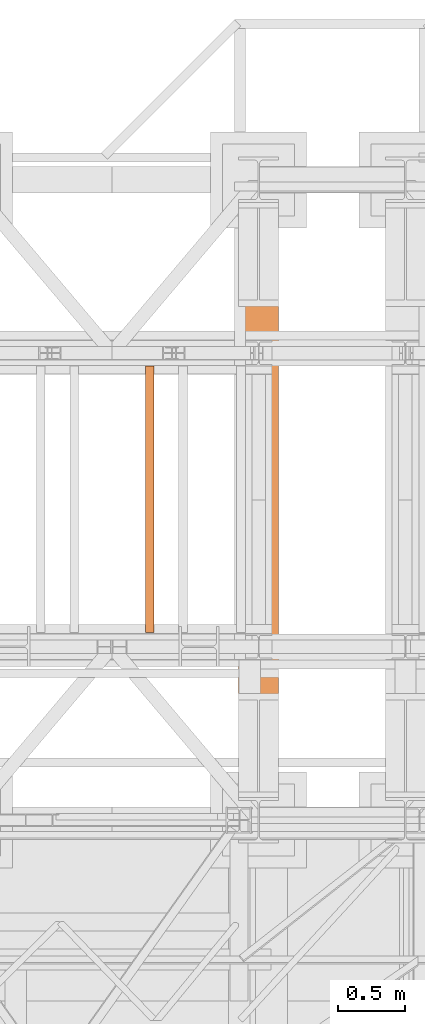
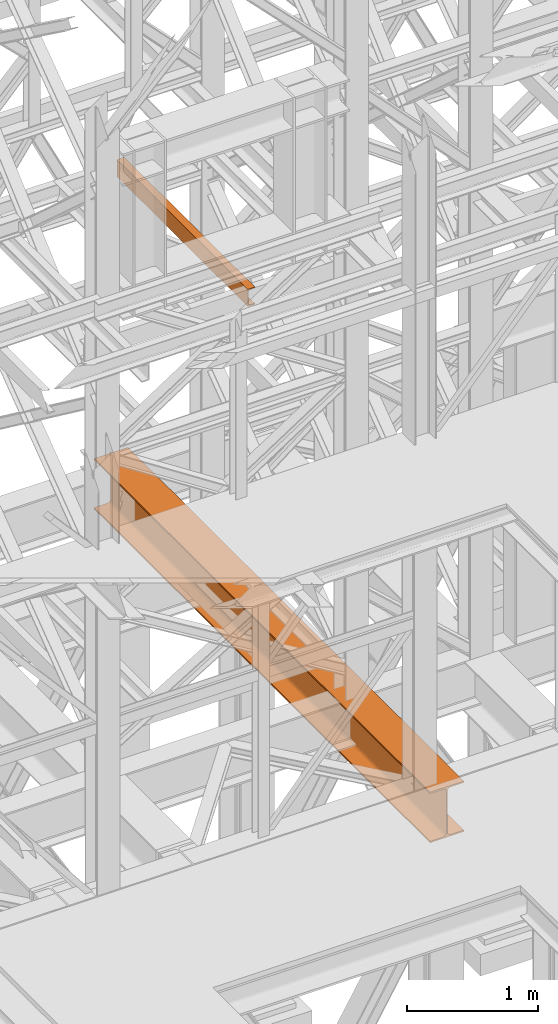
# One storey, part 159 of 208: 2 proxies.
"""IFC2X3 building model written with IfcOpenShell, lengths in millimetres."""

from ifc_helpers import new_model, entity, si_unit, converted_unit, frame, origin, origin_with_axes, place, context, subcontext, project, spatial, faceted_brep, element, save


model = new_model("IFC2X3")

# Units and contexts
model_context = context("Model", 3, precision=1e-05, world=origin())
plan_context = context("Plan", 3, precision=1e-05, world=origin())
body_context = subcontext(model_context, "Body", "Model", "MODEL_VIEW")
ifc_project = project(units=[si_unit("LENGTHUNIT", "METRE", prefix="MILLI"), converted_unit("PLANEANGLEUNIT", "DEGREE", entity("IfcPlaneAngleMeasure", 0.0174532925199433), si_unit("PLANEANGLEUNIT", "RADIAN"), dimensions=[0, 0, 0, 0, 0, 0, 0]), si_unit("AREAUNIT", "SQUARE_METRE"), si_unit("VOLUMEUNIT", "CUBIC_METRE")], contexts=[model_context, plan_context])

# Building, storey
building_placement = place(None, origin())
building = spatial("IfcBuilding", under=ifc_project, at=building_placement, CompositionType="COMPLEX")
storey_placement = place(building_placement, origin_with_axes())
storey = spatial("IfcBuildingStorey", under=building, at=storey_placement, Name="Geschoss", CompositionType="ELEMENT")

# Proxies
proxy_1_placement = place(storey_placement, frame((5343.254974489131, -17432.57439531566, 4812.990005364416), z_axis=(0.0, 0.0, 1.0), x_axis=(1.0, 0.0, 0.0)))
element("IfcBuildingElementProxy", 1, at=proxy_1_placement, inside=storey, context=body_context, shape_type="Brep", body=[
    faceted_brep([(300.0100000000002, 0.00999999999839929, 472.0100000000002), (300.0100000000002, 5140.010003576275, 472.0100000000002), (300.0100000000002, 5140.010003576275, 458.0100000000002), (300.0100000000002, 0.00999999999839929, 458.0100000000002), (300.0100000000002, 0.00999999999839929, 458.0100000000002), (300.0100000000002, 5140.010003576275, 458.0100000000002), (182.2600000000002, 5140.010003576275, 458.0100000000002), (182.2600000000002, 0.00999999999839929, 458.0100000000002), (182.2600000000002, 0.00999999999839929, 458.0100000000002), (182.2600000000002, 5140.010003576275, 458.0100000000002), (173.9165694541389, 5140.010003576275, 456.6884339422595), (173.9165694541389, 0.00999999999839929, 456.6884339422595), (173.9165694541389, 0.00999999999839929, 456.6884339422595), (173.9165694541389, 5140.010003576275, 456.6884339422595), (166.3898249342001, 5140.010003576275, 452.8534254634024), (166.3898249342001, 0.00999999999839929, 452.8534254634024), (166.3898249342001, 0.00999999999839929, 452.8534254634024), (166.3898249342001, 5140.010003576275, 452.8534254634024), (160.416574536599, 5140.010003576275, 446.8801750658013), (160.416574536599, 0.00999999999839929, 446.8801750658013), (160.416574536599, 0.00999999999839929, 446.8801750658013), (160.416574536599, 5140.010003576275, 446.8801750658013), (156.5815660577409, 5140.010003576275, 439.3534305458607), (156.5815660577409, 0.00999999999839929, 439.3534305458607), (156.5815660577409, 0.00999999999839929, 439.3534305458607), (156.5815660577409, 5140.010003576275, 439.3534305458607), (155.2600000000002, 5140.010003576275, 431.0100000000002), (155.2600000000002, 0.00999999999839929, 431.0100000000002), (155.2600000000002, 0.00999999999839929, 431.0100000000002), (155.2600000000002, 5140.010003576275, 431.0100000000002), (155.2600000000002, 5140.010003576275, 41.01000000000022), (155.2600000000002, 0.00999999999839929, 41.01000000000022), (155.2600000000002, 0.00999999999839929, 41.01000000000022), (155.2600000000002, 5140.010003576275, 41.01000000000022), (156.5815660577409, 5140.010003576275, 32.66656945413979), (156.5815660577409, 0.00999999999839929, 32.66656945413979), (156.5815660577409, 0.00999999999839929, 32.66656945413979), (156.5815660577409, 5140.010003576275, 32.66656945413979), (160.416574536599, 5140.010003576275, 25.13982493419826), (160.416574536599, 0.00999999999839929, 25.13982493419826), (160.416574536599, 0.00999999999839929, 25.13982493419826), (160.416574536599, 5140.010003576275, 25.13982493419826), (166.3898249342001, 5140.010003576275, 19.16657453659809), (166.3898249342001, 0.00999999999839929, 19.16657453659809), (166.3898249342001, 0.00999999999839929, 19.16657453659809), (166.3898249342001, 5140.010003576275, 19.16657453659809), (173.9165694541389, 5140.010003576275, 15.33156605774093), (173.9165694541389, 0.00999999999839929, 15.33156605774093), (173.9165694541389, 0.00999999999839929, 15.33156605774093), (173.9165694541389, 5140.010003576275, 15.33156605774093), (182.2600000000002, 5140.010003576275, 14.01000000000022), (182.2600000000002, 0.00999999999839929, 14.01000000000022), (182.2600000000002, 0.00999999999839929, 14.01000000000022), (182.2600000000002, 5140.010003576275, 14.01000000000022), (300.0100000000002, 5140.010003576275, 14.01000000000022), (300.0100000000002, 0.00999999999839929, 14.01000000000022), (300.0100000000002, 0.00999999999839929, 14.01000000000022), (300.0100000000002, 5140.010003576275, 14.01000000000022), (300.0100000000002, 5140.010003576275, 0.01000000000021828), (300.0100000000002, 0.00999999999839929, 0.01000000000021828), (300.0100000000002, 0.00999999999839929, 0.01000000000021828), (300.0100000000002, 5140.010003576275, 0.01000000000021828), (0.01000000000021828, 5140.010003576275, 0.01000000000021828), (0.01000000000021828, 0.00999999999839929, 0.01000000000021828), (0.01000000000021828, 0.00999999999839929, 0.01000000000021828), (0.01000000000021828, 5140.010003576275, 0.01000000000021828), (0.01000000000021828, 5140.010003576275, 14.01000000000022), (0.01000000000021828, 0.00999999999839929, 14.01000000000022), (0.01000000000021828, 0.00999999999839929, 14.01000000000022), (0.01000000000021828, 5140.010003576275, 14.01000000000022), (117.7600000000002, 5140.010003576275, 14.01000000000022), (117.7600000000002, 0.00999999999839929, 14.01000000000022), (117.7600000000002, 0.00999999999839929, 14.01000000000022), (117.7600000000002, 5140.010003576275, 14.01000000000022), (126.1034305458616, 5140.010003576275, 15.33156605774093), (126.1034305458616, 0.00999999999839929, 15.33156605774093), (126.1034305458616, 0.00999999999839929, 15.33156605774093), (126.1034305458616, 5140.010003576275, 15.33156605774093), (133.6301750658004, 5140.010003576275, 19.16657453659809), (133.6301750658004, 0.00999999999839929, 19.16657453659809), (133.6301750658004, 0.00999999999839929, 19.16657453659809), (133.6301750658004, 5140.010003576275, 19.16657453659809), (139.6034254634014, 5140.010003576275, 25.13982493419826), (139.6034254634014, 0.00999999999839929, 25.13982493419826), (139.6034254634014, 0.00999999999839929, 25.13982493419826), (139.6034254634014, 5140.010003576275, 25.13982493419826), (143.4384339422595, 5140.010003576275, 32.66656945413979), (143.4384339422595, 0.00999999999839929, 32.66656945413979), (143.4384339422595, 0.00999999999839929, 32.66656945413979), (143.4384339422595, 5140.010003576275, 32.66656945413979), (144.7600000000002, 5140.010003576275, 41.01000000000022), (144.7600000000002, 0.00999999999839929, 41.01000000000022), (144.7600000000002, 0.00999999999839929, 41.01000000000022), (144.7600000000002, 5140.010003576275, 41.01000000000022), (144.7600000000002, 5140.010003576275, 431.0100000000002), (144.7600000000002, 0.00999999999839929, 431.0100000000002), (144.7600000000002, 0.00999999999839929, 431.0100000000002), (144.7600000000002, 5140.010003576275, 431.0100000000002), (143.4384339422595, 5140.010003576275, 439.3534305458607), (143.4384339422595, 0.00999999999839929, 439.3534305458607), (143.4384339422595, 0.00999999999839929, 439.3534305458607), (143.4384339422595, 5140.010003576275, 439.3534305458607), (139.6034254634014, 5140.010003576275, 446.8801750658013), (139.6034254634014, 0.00999999999839929, 446.8801750658013), (139.6034254634014, 0.00999999999839929, 446.8801750658013), (139.6034254634014, 5140.010003576275, 446.8801750658013), (133.6301750658004, 5140.010003576275, 452.8534254634024), (133.6301750658004, 0.00999999999839929, 452.8534254634024), (133.6301750658004, 0.00999999999839929, 452.8534254634024), (133.6301750658004, 5140.010003576275, 452.8534254634024), (126.1034305458616, 5140.010003576275, 456.6884339422595), (126.1034305458616, 0.00999999999839929, 456.6884339422595), (126.1034305458616, 0.00999999999839929, 456.6884339422595), (126.1034305458616, 5140.010003576275, 456.6884339422595), (117.7600000000002, 5140.010003576275, 458.0100000000002), (117.7600000000002, 0.00999999999839929, 458.0100000000002), (117.7600000000002, 0.00999999999839929, 458.0100000000002), (117.7600000000002, 5140.010003576275, 458.0100000000002), (0.01000000000021828, 5140.010003576275, 458.0100000000002), (0.01000000000021828, 0.00999999999839929, 458.0100000000002), (0.01000000000021828, 0.00999999999839929, 458.0100000000002), (0.01000000000021828, 5140.010003576275, 458.0100000000002), (0.01000000000021828, 5140.010003576275, 472.0100000000002), (0.01000000000021828, 0.00999999999839929, 472.0100000000002), (0.01000000000021828, 0.00999999999839929, 472.0100000000002), (0.01000000000021828, 5140.010003576275, 472.0100000000002), (300.0100000000002, 5140.010003576275, 472.0100000000002), (300.0100000000002, 0.00999999999839929, 472.0100000000002), (300.0100000000002, 0.00999999999839929, 472.0100000000002), (300.0100000000002, 0.00999999999839929, 458.0100000000002), (182.2600000000002, 0.00999999999839929, 458.0100000000002), (173.9165694541389, 0.00999999999839929, 456.6884339422595), (166.3898249342001, 0.00999999999839929, 452.8534254634024), (160.416574536599, 0.00999999999839929, 446.8801750658013), (156.5815660577409, 0.00999999999839929, 439.3534305458607), (155.2600000000002, 0.00999999999839929, 431.0100000000002), (155.2600000000002, 0.00999999999839929, 41.01000000000022), (156.5815660577409, 0.00999999999839929, 32.66656945413979), (160.416574536599, 0.00999999999839929, 25.13982493419826), (166.3898249342001, 0.00999999999839929, 19.16657453659809), (173.9165694541389, 0.00999999999839929, 15.33156605774093), (182.2600000000002, 0.00999999999839929, 14.01000000000022), (300.0100000000002, 0.00999999999839929, 14.01000000000022), (300.0100000000002, 0.00999999999839929, 0.01000000000021828), (0.01000000000021828, 0.00999999999839929, 0.01000000000021828), (0.01000000000021828, 0.00999999999839929, 14.01000000000022), (117.7600000000002, 0.00999999999839929, 14.01000000000022), (126.1034305458616, 0.00999999999839929, 15.33156605774093), (133.6301750658004, 0.00999999999839929, 19.16657453659809), (139.6034254634014, 0.00999999999839929, 25.13982493419826), (143.4384339422595, 0.00999999999839929, 32.66656945413979), (144.7600000000002, 0.00999999999839929, 41.01000000000022), (144.7600000000002, 0.00999999999839929, 431.0100000000002), (143.4384339422595, 0.00999999999839929, 439.3534305458607), (139.6034254634014, 0.00999999999839929, 446.8801750658013), (133.6301750658004, 0.00999999999839929, 452.8534254634024), (126.1034305458616, 0.00999999999839929, 456.6884339422595), (117.7600000000002, 0.00999999999839929, 458.0100000000002), (0.01000000000021828, 0.00999999999839929, 458.0100000000002), (0.01000000000021828, 0.00999999999839929, 472.0100000000002), (300.0100000000002, 5140.010003576275, 472.0100000000002), (0.01000000000021828, 5140.010003576275, 472.0100000000002), (0.01000000000021828, 5140.010003576275, 458.0100000000002), (117.7600000000002, 5140.010003576275, 458.0100000000002), (126.1034305458616, 5140.010003576275, 456.6884339422595), (133.6301750658004, 5140.010003576275, 452.8534254634024), (139.6034254634014, 5140.010003576275, 446.8801750658013), (143.4384339422595, 5140.010003576275, 439.3534305458607), (144.7600000000002, 5140.010003576275, 431.0100000000002), (144.7600000000002, 5140.010003576275, 41.01000000000022), (143.4384339422595, 5140.010003576275, 32.66656945413979), (139.6034254634014, 5140.010003576275, 25.13982493419826), (133.6301750658004, 5140.010003576275, 19.16657453659809), (126.1034305458616, 5140.010003576275, 15.33156605774093), (117.7600000000002, 5140.010003576275, 14.01000000000022), (0.01000000000021828, 5140.010003576275, 14.01000000000022), (0.01000000000021828, 5140.010003576275, 0.01000000000021828), (300.0100000000002, 5140.010003576275, 0.01000000000021828), (300.0100000000002, 5140.010003576275, 14.01000000000022), (182.2600000000002, 5140.010003576275, 14.01000000000022), (173.9165694541389, 5140.010003576275, 15.33156605774093), (166.3898249342001, 5140.010003576275, 19.16657453659809), (160.416574536599, 5140.010003576275, 25.13982493419826), (156.5815660577409, 5140.010003576275, 32.66656945413979), (155.2600000000002, 5140.010003576275, 41.01000000000022), (155.2600000000002, 5140.010003576275, 431.0100000000002), (156.5815660577409, 5140.010003576275, 439.3534305458607), (160.416574536599, 5140.010003576275, 446.8801750658013), (166.3898249342001, 5140.010003576275, 452.8534254634024), (173.9165694541389, 5140.010003576275, 456.6884339422595), (182.2600000000002, 5140.010003576275, 458.0100000000002), (300.0100000000002, 5140.010003576275, 458.0100000000002)], [[[0, 1, 2, 3]], [[4, 5, 6, 7]], [[8, 9, 10, 11]], [[12, 13, 14, 15]], [[16, 17, 18, 19]], [[20, 21, 22, 23]], [[24, 25, 26, 27]], [[28, 29, 30, 31]], [[32, 33, 34, 35]], [[36, 37, 38, 39]], [[40, 41, 42, 43]], [[44, 45, 46, 47]], [[48, 49, 50, 51]], [[52, 53, 54, 55]], [[56, 57, 58, 59]], [[60, 61, 62, 63]], [[64, 65, 66, 67]], [[68, 69, 70, 71]], [[72, 73, 74, 75]], [[76, 77, 78, 79]], [[80, 81, 82, 83]], [[84, 85, 86, 87]], [[88, 89, 90, 91]], [[92, 93, 94, 95]], [[96, 97, 98, 99]], [[100, 101, 102, 103]], [[104, 105, 106, 107]], [[108, 109, 110, 111]], [[112, 113, 114, 115]], [[116, 117, 118, 119]], [[120, 121, 122, 123]], [[124, 125, 126, 127]], [[128, 129, 130, 131, 132, 133, 134, 135, 136, 137, 138, 139, 140, 141, 142, 143, 144, 145, 146, 147, 148, 149, 150, 151, 152, 153, 154, 155, 156, 157, 158, 159]], [[160, 161, 162, 163, 164, 165, 166, 167, 168, 169, 170, 171, 172, 173, 174, 175, 176, 177, 178, 179, 180, 181, 182, 183, 184, 185, 186, 187, 188, 189, 190, 191]]], orient=[[False], [False], [False], [False], [False], [False], [False], [False], [False], [False], [False], [False], [False], [False], [False], [False], [False], [False], [False], [False], [False], [False], [False], [False], [False], [False], [False], [False], [False], [False], [False], [False], [False], [False]]),
])
proxy_2_placement = place(storey_placement, frame((4643.302373794972, -15857.57439274273, 9109.989999999998), z_axis=(0.0, 0.0, 1.0), x_axis=(1.0, 0.0, 0.0)))
element("IfcBuildingElementProxy", 2, at=proxy_2_placement, inside=storey, context=body_context, shape_type="Brep", body=[
    faceted_brep([(0.01000000000203727, 2000.009997019768, 160.0100000000002), (65.01000000000204, 2000.009997019768, 160.0100000000002), (65.01000000000022, 0.01000000000021828, 160.0100000000002), (0.01000000000021828, 0.01000000000021828, 160.0100000000002), (65.01000000000204, 2000.009997019768, 160.0100000000002), (65.01000000000204, 2000.009997019768, 156.8875719297539), (65.01000000000022, 0.01000000000021828, 156.8875719297539), (65.01000000000022, 0.01000000000021828, 160.0100000000002), (65.01000000000204, 2000.009997019768, 156.8875719297539), (64.76726342282927, 2000.009997019768, 155.2717110918293), (64.76726342282745, 0.01000000000021828, 155.2717110918293), (65.01000000000022, 0.01000000000021828, 156.8875719297539), (64.76726342282927, 2000.009997019768, 155.2717110918293), (64.06053228585733, 2000.009997019768, 153.7984655565542), (64.06053228585915, 0.01000000000021828, 153.7984655565542), (64.76726342282745, 0.01000000000021828, 155.2717110918293), (64.06053228585733, 2000.009997019768, 153.7984655565542), (62.95215163847024, 2000.009997019768, 152.5978732961266), (62.95215163846842, 0.01000000000021828, 152.5978732961266), (64.06053228585915, 0.01000000000021828, 153.7984655565542), (62.95215163847024, 2000.009997019768, 152.5978732961266), (61.53995641148504, 2000.009997019768, 151.7759086082897), (61.53995641148322, 0.01000000000021828, 151.7759086082897), (62.95215163846842, 0.01000000000021828, 152.5978732961266), (61.53995641148504, 2000.009997019768, 151.7759086082897), (59.9485987225562, 2000.009997019768, 151.4050878978051), (59.94859872255438, 0.01000000000021828, 151.4050878978051), (61.53995641148322, 0.01000000000021828, 151.7759086082897), (59.9485987225562, 2000.009997019768, 151.4050878978051), (17.1726751660317, 2000.009997019768, 147.9830140132835), (17.17267516602988, 0.01000000000021828, 147.9830140132835), (59.94859872255438, 0.01000000000021828, 151.4050878978051), (17.1726751660317, 2000.009997019768, 147.9830140132835), (14.20840820801095, 2000.009997019768, 147.318026761528), (14.20840820800913, 0.01000000000021828, 147.318026761528), (17.17267516602988, 0.01000000000021828, 147.9830140132835), (14.20840820801095, 2000.009997019768, 147.318026761528), (11.43861959928836, 2000.009997019768, 145.7058782528511), (11.43861959929018, 0.01000000000021828, 145.7058782528511), (14.20840820800913, 0.01000000000021828, 147.318026761528), (11.43861959928836, 2000.009997019768, 145.7058782528511), (9.3226201815487, 2000.009997019768, 143.4138384829421), (9.322620181546881, 0.01000000000021828, 143.4138384829421), (11.43861959929018, 0.01000000000021828, 145.7058782528511), (9.3226201815487, 2000.009997019768, 143.4138384829421), (7.973406192788389, 2000.009997019768, 140.6012788246917), (7.97340619278657, 0.01000000000021828, 140.6012788246917), (9.322620181546881, 0.01000000000021828, 143.4138384829421), (7.973406192788389, 2000.009997019768, 140.6012788246917), (7.510000000002037, 2000.009997019768, 137.5164535886543), (7.510000000000218, 0.01000000000021828, 137.5164535886543), (7.97340619278657, 0.01000000000021828, 140.6012788246917), (7.510000000002037, 2000.009997019768, 137.5164535886543), (7.510000000002037, 2000.009997019768, 22.503546411348), (7.510000000000218, 0.01000000000021828, 22.503546411348), (7.510000000000218, 0.01000000000021828, 137.5164535886543), (7.510000000002037, 2000.009997019768, 22.503546411348), (7.973406192788389, 2000.009997019768, 19.41872117530875), (7.97340619278657, 0.01000000000021828, 19.41872117530875), (7.510000000000218, 0.01000000000021828, 22.503546411348), (7.973406192788389, 2000.009997019768, 19.41872117530875), (9.3226201815487, 2000.009997019768, 16.60616151705835), (9.322620181546881, 0.01000000000021828, 16.60616151705835), (7.97340619278657, 0.01000000000021828, 19.41872117530875), (9.3226201815487, 2000.009997019768, 16.60616151705835), (11.43861959928836, 2000.009997019768, 14.31412174714933), (11.43861959929018, 0.01000000000021828, 14.31412174714933), (9.322620181546881, 0.01000000000021828, 16.60616151705835), (11.43861959928836, 2000.009997019768, 14.31412174714933), (14.13462866898408, 2000.009997019768, 12.74491643400688), (14.1346286689859, 0.01000000000021828, 12.74491643400688), (11.43861959929018, 0.01000000000021828, 14.31412174714933), (14.13462866898408, 2000.009997019768, 12.74491643400688), (17.1726751660317, 2000.009997019768, 12.03698598671872), (17.17267516602988, 0.01000000000021828, 12.03698598671872), (14.1346286689859, 0.01000000000021828, 12.74491643400688), (17.1726751660317, 2000.009997019768, 12.03698598671872), (59.9485987225562, 2000.009997019768, 8.614912102195376), (59.94859872255438, 0.01000000000021828, 8.614912102195376), (17.17267516602988, 0.01000000000021828, 12.03698598671872), (59.9485987225562, 2000.009997019768, 8.614912102195376), (61.53995641148504, 2000.009997019768, 8.244091391710754), (61.53995641148322, 0.01000000000021828, 8.244091391710754), (59.94859872255438, 0.01000000000021828, 8.614912102195376), (61.53995641148504, 2000.009997019768, 8.244091391710754), (62.95215163847024, 2000.009997019768, 7.422126703873801), (62.95215163846842, 0.01000000000021828, 7.422126703873801), (61.53995641148322, 0.01000000000021828, 8.244091391710754), (62.95215163847024, 2000.009997019768, 7.422126703873801), (64.06053228585733, 2000.009997019768, 6.221534443446217), (64.06053228585915, 0.01000000000021828, 6.221534443446217), (62.95215163846842, 0.01000000000021828, 7.422126703873801), (64.06053228585733, 2000.009997019768, 6.221534443446217), (64.76726342282927, 2000.009997019768, 4.748288908172981), (64.76726342282745, 0.01000000000021828, 4.748288908172981), (64.06053228585915, 0.01000000000021828, 6.221534443446217), (64.76726342282927, 2000.009997019768, 4.748288908172981), (65.01000000000204, 2000.009997019768, 0.01000000000021828), (65.01000000000022, 0.01000000000021828, 0.01000000000021828), (64.76726342282745, 0.01000000000021828, 4.748288908172981), (65.01000000000204, 2000.009997019768, 0.01000000000021828), (0.01000000000203727, 2000.009997019768, 0.01000000000021828), (0.01000000000021828, 0.01000000000021828, 0.01000000000021828), (65.01000000000022, 0.01000000000021828, 0.01000000000021828), (0.01000000000203727, 2000.009997019768, 0.01000000000021828), (0.01000000000203727, 2000.009997019768, 160.0100000000002), (0.01000000000021828, 0.01000000000021828, 160.0100000000002), (0.01000000000021828, 0.01000000000021828, 0.01000000000021828), (0.01000000000203727, 2000.009997019768, 160.0100000000002), (0.01000000000203727, 2000.009997019768, 0.01000000000021828), (65.01000000000204, 2000.009997019768, 0.01000000000021828), (64.76726342282927, 2000.009997019768, 4.748288908172981), (64.06053228585733, 2000.009997019768, 6.221534443446217), (62.95215163847024, 2000.009997019768, 7.422126703873801), (61.53995641148504, 2000.009997019768, 8.244091391710754), (59.9485987225562, 2000.009997019768, 8.614912102195376), (17.1726751660317, 2000.009997019768, 12.03698598671872), (14.13462866898408, 2000.009997019768, 12.74491643400688), (11.43861959928836, 2000.009997019768, 14.31412174714933), (9.3226201815487, 2000.009997019768, 16.60616151705835), (7.973406192788389, 2000.009997019768, 19.41872117530875), (7.510000000002037, 2000.009997019768, 22.503546411348), (7.510000000002037, 2000.009997019768, 137.5164535886543), (7.973406192788389, 2000.009997019768, 140.6012788246917), (9.3226201815487, 2000.009997019768, 143.4138384829421), (11.43861959928836, 2000.009997019768, 145.7058782528511), (14.20840820801095, 2000.009997019768, 147.318026761528), (17.1726751660317, 2000.009997019768, 147.9830140132835), (59.9485987225562, 2000.009997019768, 151.4050878978051), (61.53995641148504, 2000.009997019768, 151.7759086082897), (62.95215163847024, 2000.009997019768, 152.5978732961266), (64.06053228585733, 2000.009997019768, 153.7984655565542), (64.76726342282927, 2000.009997019768, 155.2717110918293), (65.01000000000204, 2000.009997019768, 156.8875719297539), (65.01000000000204, 2000.009997019768, 160.0100000000002), (0.01000000000021828, 0.01000000000021828, 160.0100000000002), (65.01000000000022, 0.01000000000021828, 160.0100000000002), (65.01000000000022, 0.01000000000021828, 156.8875719297539), (64.76726342282745, 0.01000000000021828, 155.2717110918293), (64.06053228585915, 0.01000000000021828, 153.7984655565542), (62.95215163846842, 0.01000000000021828, 152.5978732961266), (61.53995641148322, 0.01000000000021828, 151.7759086082897), (59.94859872255438, 0.01000000000021828, 151.4050878978051), (17.17267516602988, 0.01000000000021828, 147.9830140132835), (14.20840820800913, 0.01000000000021828, 147.318026761528), (11.43861959929018, 0.01000000000021828, 145.7058782528511), (9.322620181546881, 0.01000000000021828, 143.4138384829421), (7.97340619278657, 0.01000000000021828, 140.6012788246917), (7.510000000000218, 0.01000000000021828, 137.5164535886543), (7.510000000000218, 0.01000000000021828, 22.503546411348), (7.97340619278657, 0.01000000000021828, 19.41872117530875), (9.322620181546881, 0.01000000000021828, 16.60616151705835), (11.43861959929018, 0.01000000000021828, 14.31412174714933), (14.1346286689859, 0.01000000000021828, 12.74491643400688), (17.17267516602988, 0.01000000000021828, 12.03698598671872), (59.94859872255438, 0.01000000000021828, 8.614912102195376), (61.53995641148322, 0.01000000000021828, 8.244091391710754), (62.95215163846842, 0.01000000000021828, 7.422126703873801), (64.06053228585915, 0.01000000000021828, 6.221534443446217), (64.76726342282745, 0.01000000000021828, 4.748288908172981), (65.01000000000022, 0.01000000000021828, 0.01000000000021828), (0.01000000000021828, 0.01000000000021828, 0.01000000000021828)], [[[0, 1, 2, 3]], [[4, 5, 6, 7]], [[8, 9, 10, 11]], [[12, 13, 14, 15]], [[16, 17, 18, 19]], [[20, 21, 22, 23]], [[24, 25, 26, 27]], [[28, 29, 30, 31]], [[32, 33, 34, 35]], [[36, 37, 38, 39]], [[40, 41, 42, 43]], [[44, 45, 46, 47]], [[48, 49, 50, 51]], [[52, 53, 54, 55]], [[56, 57, 58, 59]], [[60, 61, 62, 63]], [[64, 65, 66, 67]], [[68, 69, 70, 71]], [[72, 73, 74, 75]], [[76, 77, 78, 79]], [[80, 81, 82, 83]], [[84, 85, 86, 87]], [[88, 89, 90, 91]], [[92, 93, 94, 95]], [[96, 97, 98, 99]], [[100, 101, 102, 103]], [[104, 105, 106, 107]], [[108, 109, 110, 111, 112, 113, 114, 115, 116, 117, 118, 119, 120, 121, 122, 123, 124, 125, 126, 127, 128, 129, 130, 131, 132, 133, 134]], [[135, 136, 137, 138, 139, 140, 141, 142, 143, 144, 145, 146, 147, 148, 149, 150, 151, 152, 153, 154, 155, 156, 157, 158, 159, 160, 161]]], orient=[[False], [False], [False], [False], [False], [False], [False], [False], [False], [False], [False], [False], [False], [False], [False], [False], [False], [False], [False], [False], [False], [False], [False], [False], [False], [False], [False], [False], [False]]),
])

save(model, "model.ifc")
